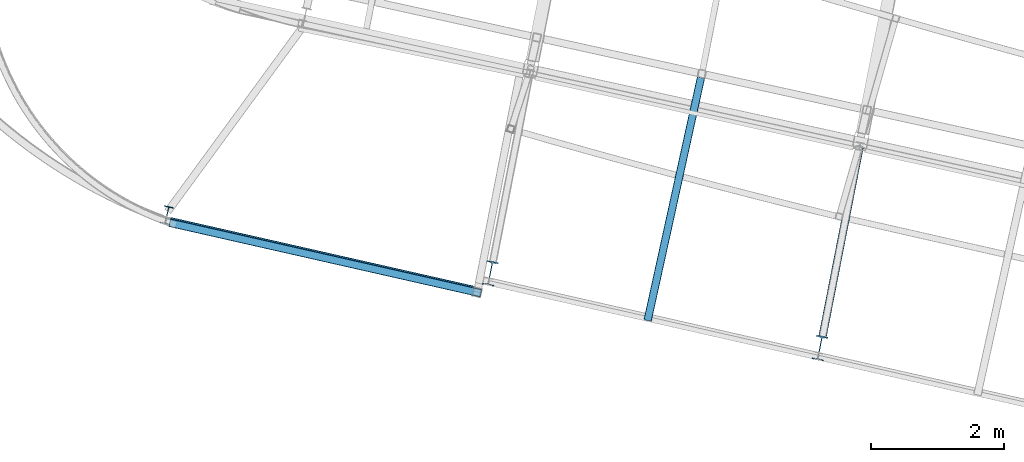
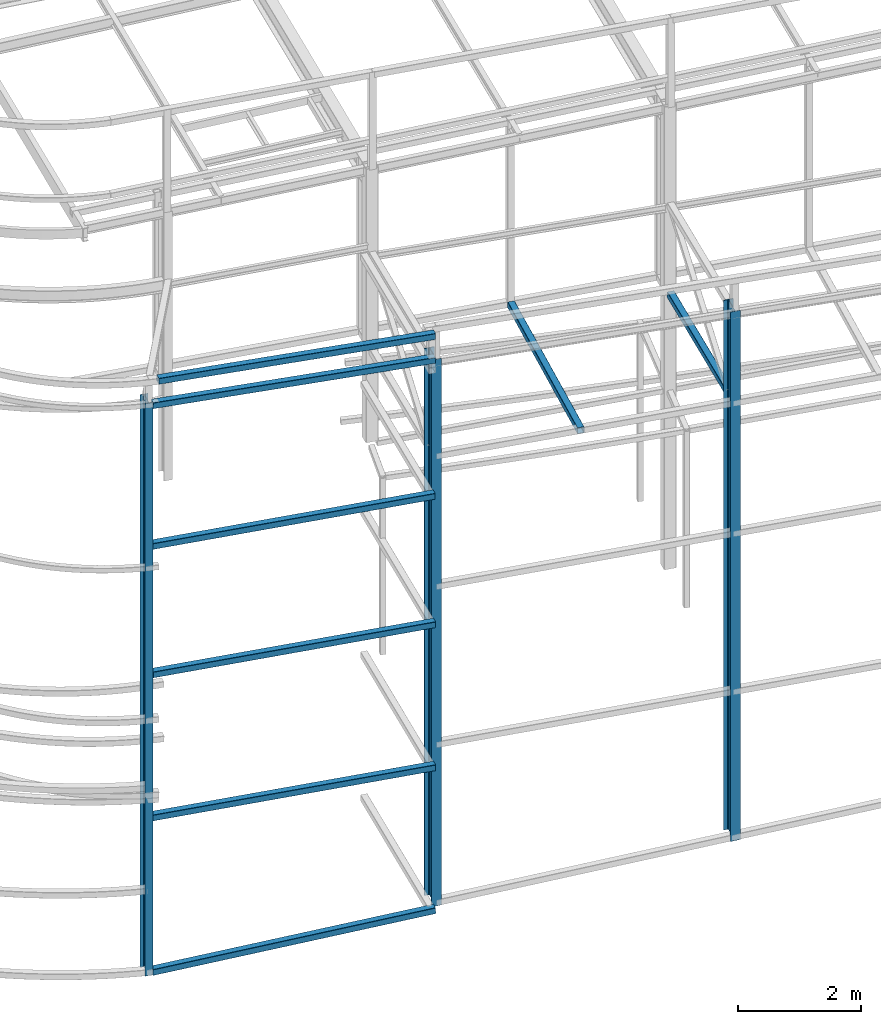
# One storey, part 14 of 215: 11 beams, 11 elements without a shape of their own.
"""IFC2X3 building model written with IfcOpenShell, lengths in millimetres."""

from ifc_helpers import new_model, si_unit, frame, origin_with_axes, origin_2d_with_axis, place, context, subcontext, project, spatial, hollow_rectangle, i_section, extrude, clip, halfspace, material, type_object, element, aggregate, save


model = new_model("IFC2X3")

# Units and contexts
model_context = context("Model", 3, precision=1e-05, world=origin_with_axes())
body_context = subcontext(model_context, "Body", "Model", "MODEL_VIEW")
ifc_project = project(units=[si_unit("LENGTHUNIT", "METRE", prefix="MILLI"), si_unit("AREAUNIT", "SQUARE_METRE"), si_unit("VOLUMEUNIT", "CUBIC_METRE"), si_unit("MASSUNIT", "GRAM", prefix="KILO"), si_unit("TIMEUNIT", "SECOND"), si_unit("PLANEANGLEUNIT", "RADIAN"), si_unit("SOLIDANGLEUNIT", "STERADIAN"), si_unit("THERMODYNAMICTEMPERATUREUNIT", "DEGREE_CELSIUS"), si_unit("LUMINOUSINTENSITYUNIT", "LUMEN")], contexts=[model_context])

# Site, building, storey
site_placement = place(None, origin_with_axes())
site = spatial("IfcSite", under=ifc_project, at=site_placement, CompositionType="ELEMENT")
building_placement = place(site_placement, origin_with_axes())
building = spatial("IfcBuilding", under=site, at=building_placement, Name="Undefined", CompositionType="ELEMENT")
storey_placement = place(building_placement, origin_with_axes())
storey = spatial("IfcBuildingStorey", under=building, at=storey_placement, Name="Undefined", CompositionType="ELEMENT", Elevation=0.0)

# Assembly, beam
assembly_1_placement = place(storey_placement, origin_with_axes())
assembly_1 = element("IfcElementAssembly", 1, at=assembly_1_placement, inside=storey, Name="Steel Assembly", AssemblyPlace="NOTDEFINED", PredefinedType="RIGID_FRAME")
ifc_material = material(Name="STEEL/S275JR")
beam_type_1 = type_object("IfcBeamType", Name="IPE270", PredefinedType="NOTDEFINED")
beam_1_placement = place(assembly_1_placement, frame((39568.220511115, 7970.61317435957, 10913.7613874737), z_axis=(0.220975240014642, 0.975279418064624, 0.0), x_axis=(0.0, 0.0, -1.0)))
beam_1 = element("IfcBeam", 2, at=beam_1_placement, type_object=beam_type_1, material=ifc_material, Name="MONTANT", ObjectType="IPE270", context=body_context, shape_type="SweptSolid", body=[
    extrude(i_section(OverallWidth=135.0, OverallDepth=270.0, WebThickness=6.599999905, FlangeThickness=10.19999981, FilletRadius=15.0, at=origin_2d_with_axis()), frame((11363.761587995, 0.0, 0.0), z_axis=(-1.0, 0.0, 0.0), x_axis=(-6.93889390390723e-18, -1.0, -3.46944695195361e-18)), (0.0, 0.0, 1.0), 11363.8),
])
aggregate(assembly_1, [beam_1])

assembly_2_placement = place(storey_placement, origin_with_axes())
assembly_2 = element("IfcElementAssembly", 3, at=assembly_2_placement, inside=storey, Name="Steel Assembly", AssemblyPlace="NOTDEFINED", PredefinedType="RIGID_FRAME")
beam_type_2 = type_object("IfcBeamType", PredefinedType="NOTDEFINED")
beam_2_placement = place(assembly_2_placement, frame((44298.0179313007, 6796.43827342263, 11234.7334013033), z_axis=(0.0179466319965004, -0.00406597099920729, 0.999830678805074), x_axis=(-0.975124754494371, 0.220891601111988, 0.0184014600093292)))
beam_2 = element("IfcBeam", 4, at=beam_2_placement, type_object=beam_type_2, material=ifc_material, Name="LISSE", context=body_context, shape_type="SweptSolid", body=[
    extrude(hollow_rectangle(XDim=120.0, YDim=120.0, WallThickness=4.0, InnerFilletRadius=4.0, OuterFilletRadius=8.0, at=origin_2d_with_axis()), frame((4712.03802041382, 8.1017703841676e-14, 1.63481659474143e-14), z_axis=(-1.0, 0.0, 0.0), x_axis=(-6.93889390390723e-18, -1.0, -3.46944695195361e-18)), (0.0, 0.0, 1.0), 4712.0),
])
aggregate(assembly_2, [beam_2])

assembly_3_placement = place(storey_placement, origin_with_axes())
assembly_3 = element("IfcElementAssembly", 5, at=assembly_3_placement, inside=storey, Name="Steel Assembly", AssemblyPlace="NOTDEFINED", PredefinedType="RIGID_FRAME")
beam_type_3 = type_object("IfcBeamType", PredefinedType="NOTDEFINED")
beam_3_placement = place(assembly_3_placement, frame((47609.5178350867, 10043.392658855, 8706.00019362804), z_axis=(0.976696868550088, -0.214623453901133, -1.0000003380751e-09), x_axis=(-0.214623453901134, -0.976696868550088, 0.0)))
beam_3 = element("IfcBeam", 6, at=beam_3_placement, type_object=beam_type_3, material=ifc_material, Name="LISSE", context=body_context, shape_type="SweptSolid", body=[
    extrude(hollow_rectangle(XDim=120.0, YDim=120.0, WallThickness=5.0, InnerFilletRadius=5.0, OuterFilletRadius=10.0, at=origin_2d_with_axis()), frame((3743.15465452788, -1.93516560000818e-22, 1.03893412054742e-13), z_axis=(-1.0, 0.0, 0.0), x_axis=(-6.93889390390723e-18, -1.0, -3.46944695195361e-18)), (0.0, 0.0, 1.0), 3743.2),
])
aggregate(assembly_3, [beam_3])

assembly_4_placement = place(storey_placement, origin_with_axes())
assembly_4 = element("IfcElementAssembly", 7, at=assembly_4_placement, inside=storey, Name="Steel Assembly", AssemblyPlace="NOTDEFINED", PredefinedType="RIGID_FRAME")
beam_4_placement = place(assembly_4_placement, frame((39609.2048264203, 7858.87314105868, 2677.30165468273), z_axis=(0.220975588983775, 0.975279338928384, -1.1518999999289e-05), x_axis=(0.975279338993088, -0.220975588998434, 0.0)))
beam_4 = element("IfcBeam", 8, at=beam_4_placement, type_object=beam_type_3, material=ifc_material, Name="LISSE", context=body_context, shape_type="SweptSolid", body=[
    extrude(hollow_rectangle(XDim=120.0, YDim=120.0, WallThickness=5.0, InnerFilletRadius=5.0, OuterFilletRadius=10.0, at=origin_2d_with_axis()), frame((4806.77716071487, 4.54747350886464e-13, 0.0), z_axis=(-1.0, 0.0, 0.0), x_axis=(-6.93889390390723e-18, -1.0, -3.46944695195361e-18)), (0.0, 0.0, 1.0), 4806.8),
])
aggregate(assembly_4, [beam_4])

assembly_5_placement = place(storey_placement, origin_with_axes())
assembly_5 = element("IfcElementAssembly", 9, at=assembly_5_placement, inside=storey, Name="Steel Assembly", AssemblyPlace="NOTDEFINED", PredefinedType="RIGID_FRAME")
beam_5_placement = place(assembly_5_placement, frame((39607.5726646426, 7859.38998930325, -390.069826342418), z_axis=(0.220975588983775, 0.975279338928384, -1.1518999999289e-05), x_axis=(0.974158735044356, -0.22072168601005, 0.0479238590021821)))
beam_5 = element("IfcBeam", 10, at=beam_5_placement, type_object=beam_type_3, material=ifc_material, Name="LISSE", context=body_context, shape_type="SweptSolid", body=[
    extrude(hollow_rectangle(XDim=120.0, YDim=120.0, WallThickness=5.0, InnerFilletRadius=5.0, OuterFilletRadius=10.0, at=origin_2d_with_axis()), frame((4815.42021702089, 0.0, -6.0977332996538e-14), z_axis=(-1.0, 0.0, 0.0), x_axis=(-6.93889390390723e-18, -1.0, -3.46944695195361e-18)), (0.0, 0.0, 1.0), 4815.4),
])
aggregate(assembly_5, [beam_5])

assembly_6_placement = place(storey_placement, origin_with_axes())
assembly_6 = element("IfcElementAssembly", 11, at=assembly_6_placement, inside=storey, Name="Steel Assembly", AssemblyPlace="NOTDEFINED", PredefinedType="RIGID_FRAME")
beam_6_placement = place(assembly_6_placement, frame((49996.6599024904, 8992.65837589273, 8710.00002350382), z_axis=(0.0, 0.0, 1.0), x_axis=(-0.191859508000518, -0.981422401002646, -1.00000033853845e-09)))
beam_6 = element("IfcBeam", 12, at=beam_6_placement, type_object=beam_type_3, material=ifc_material, Name="POUTRE", context=body_context, shape_type="SweptSolid", body=[
    extrude(hollow_rectangle(XDim=120.0, YDim=120.0, WallThickness=5.0, InnerFilletRadius=5.0, OuterFilletRadius=10.0, at=origin_2d_with_axis()), frame((2899.79442997003, 7.27651396735187e-12, -1.81898940354586e-12), z_axis=(-1.0, 0.0, 0.0), x_axis=(-6.93889390390723e-18, -1.0, -3.46944695195361e-18)), (0.0, 0.0, 1.0), 2899.8),
])
aggregate(assembly_6, [beam_6])

assembly_7_placement = place(storey_placement, origin_with_axes())
assembly_7 = element("IfcElementAssembly", 13, at=assembly_7_placement, inside=storey, Name="Steel Assembly", AssemblyPlace="NOTDEFINED", PredefinedType="RIGID_FRAME")
beam_7_placement = place(assembly_7_placement, frame((39610.2970534113, 7858.625504057, 5514.99536160709), z_axis=(0.220944890020541, 0.975286294090676, -1.1519000000751e-05), x_axis=(0.975286294155231, -0.220944890035166, -5.52000000081266e-07)))
beam_7 = element("IfcBeam", 14, at=beam_7_placement, type_object=beam_type_3, material=ifc_material, Name="LISSE", context=body_context, shape_type="SweptSolid", body=[
    extrude(hollow_rectangle(XDim=120.0, YDim=120.0, WallThickness=5.0, InnerFilletRadius=5.0, OuterFilletRadius=10.0, at=origin_2d_with_axis()), frame((4805.6553263743, -9.09490631224534e-13, 8.98403593369628e-14), z_axis=(-1.0, 0.0, 0.0), x_axis=(-6.93889390390723e-18, -1.0, -3.46944695195361e-18)), (0.0, 0.0, 1.0), 4805.7),
])
aggregate(assembly_7, [beam_7])

assembly_8_placement = place(storey_placement, origin_with_axes())
assembly_8 = element("IfcElementAssembly", 15, at=assembly_8_placement, inside=storey, Name="Steel Assembly", AssemblyPlace="NOTDEFINED", PredefinedType="RIGID_FRAME")
beam_8_placement = place(assembly_8_placement, frame((39613.1651879388, 7883.5281822755, 8046.32045138229), z_axis=(0.220975588983775, 0.975279338928384, -1.1518999999289e-05), x_axis=(0.975279338993088, -0.220975588998434, 0.0)))
beam_8 = element("IfcBeam", 16, at=beam_8_placement, type_object=beam_type_3, material=ifc_material, Name="LISSE", context=body_context, shape_type="SweptSolid", body=[
    extrude(hollow_rectangle(XDim=120.0, YDim=120.0, WallThickness=5.0, InnerFilletRadius=5.0, OuterFilletRadius=10.0, at=origin_2d_with_axis()), frame((4808.36285539067, -2.03642088043483e-18, -1.33458878820177e-13), z_axis=(-1.0, 0.0, 0.0), x_axis=(-6.93889390390723e-18, -1.0, -3.46944695195361e-18)), (0.0, 0.0, 1.0), 4808.4),
])
aggregate(assembly_8, [beam_8])

assembly_9_placement = place(storey_placement, origin_with_axes())
assembly_9 = element("IfcElementAssembly", 17, at=assembly_9_placement, inside=storey, Name="Steel Assembly", AssemblyPlace="NOTDEFINED", PredefinedType="RIGID_FRAME")
beam_9_placement = place(assembly_9_placement, frame((39609.8335841857, 7858.97246044564, 10855.3570209528), z_axis=(-0.0193728959925657, 0.00439052799831488, -0.99980268761629), x_axis=(0.97508690267699, -0.220931994926813, -0.0198641849934198)))
beam_9 = element("IfcBeam", 18, at=beam_9_placement, type_object=beam_type_3, material=ifc_material, Name="LISSE", context=body_context, shape_type="SweptSolid", body=[
    extrude(hollow_rectangle(XDim=120.0, YDim=120.0, WallThickness=5.0, InnerFilletRadius=5.0, OuterFilletRadius=10.0, at=origin_2d_with_axis()), frame((4806.48670392965, -1.50072604896135e-13, -1.81898940354586e-12), z_axis=(-1.0, 0.0, 0.0), x_axis=(-6.93889390390723e-18, -1.0, -3.46944695195361e-18)), (0.0, 0.0, 1.0), 4806.5),
])
aggregate(assembly_9, [beam_9])

assembly_10_placement = place(storey_placement, origin_with_axes())
assembly_10 = element("IfcElementAssembly", 19, at=assembly_10_placement, inside=storey, Name="Steel Assembly", AssemblyPlace="NOTDEFINED", PredefinedType="RIGID_FRAME")
beam_type_4 = type_object("IfcBeamType", Name="IPE360", PredefinedType="NOTDEFINED")
beam_10_placement = place(assembly_10_placement, frame((49399.9359789229, 5971.22003398683, 10534.2845184512), z_axis=(0.191859470081235, 0.981422408415534, 0.0), x_axis=(0.0, 0.0, -1.0)))
beam_10 = element("IfcBeam", 20, at=beam_10_placement, type_object=beam_type_4, material=ifc_material, Name="MONTANT", ObjectType="IPE360", context=body_context, shape_type="Clipping", body=[
    clip(extrude(i_section(OverallWidth=170.0, OverallDepth=360.0, WebThickness=8.0, FlangeThickness=12.69999981, FilletRadius=18.0, at=origin_2d_with_axis()), frame((10510.5665271076, 7.27595761418343e-12, -1.81898940354586e-12), z_axis=(-1.0, 0.0, 0.0), x_axis=(-6.93889390390723e-18, -1.0, -3.46944695195361e-18)), (0.0, 0.0, 1.0), 10510.6), halfspace(frame((10512.9047660394, 158.689785024872, -628.030383872778), z_axis=(-0.998850991769565, 0.0479026806605242, 0.0014245794090564), x_axis=(-1.0230287445127e-09, -0.0297259118404429, 0.999558087439271)), True)),
])
aggregate(assembly_10, [beam_10])

assembly_11_placement = place(storey_placement, origin_with_axes())
assembly_11 = element("IfcElementAssembly", 21, at=assembly_11_placement, inside=storey, Name="Steel Assembly", AssemblyPlace="NOTDEFINED", PredefinedType="RIGID_FRAME")
beam_11_placement = place(assembly_11_placement, frame((44436.5397743543, 7095.81007033678, 10635.3973733574), z_axis=(0.191859470081235, 0.981422408415534, 0.0), x_axis=(0.0, 0.0, -1.0)))
beam_11 = element("IfcBeam", 22, at=beam_11_placement, type_object=beam_type_4, material=ifc_material, Name="MONTANT", ObjectType="IPE360", context=body_context, shape_type="Clipping", body=[
    clip(extrude(i_section(OverallWidth=170.0, OverallDepth=360.0, WebThickness=8.0, FlangeThickness=12.69999981, FilletRadius=18.0, at=origin_2d_with_axis()), frame((10855.8542687169, 0.0, 1.81898940354586e-12), z_axis=(-1.0, 0.0, 0.0), x_axis=(-6.93889390390723e-18, -1.0, -3.46944695195361e-18)), (0.0, 0.0, 1.0), 10855.9), halfspace(frame((10858.3290408542, 161.538449617699, -628.08792799175), z_axis=(-0.998850991769565, 0.0479026806605242, 0.0014245794090564), x_axis=(-1.0230287445127e-09, -0.0297259118404429, 0.999558087439271)), True)),
])
aggregate(assembly_11, [beam_11])

save(model, "model.ifc")
